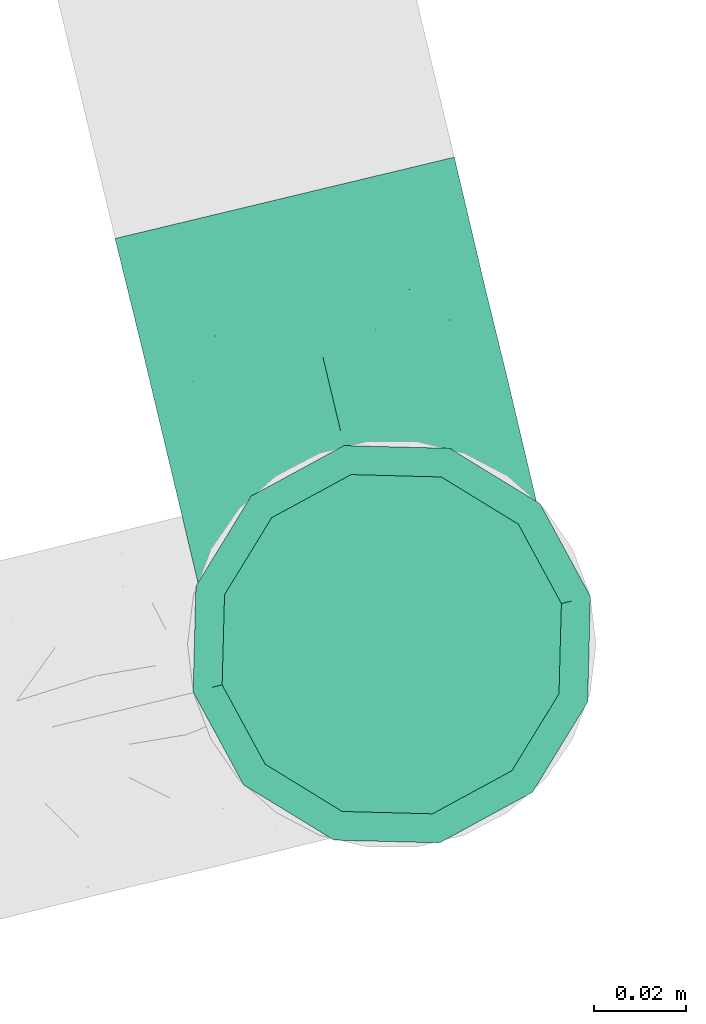
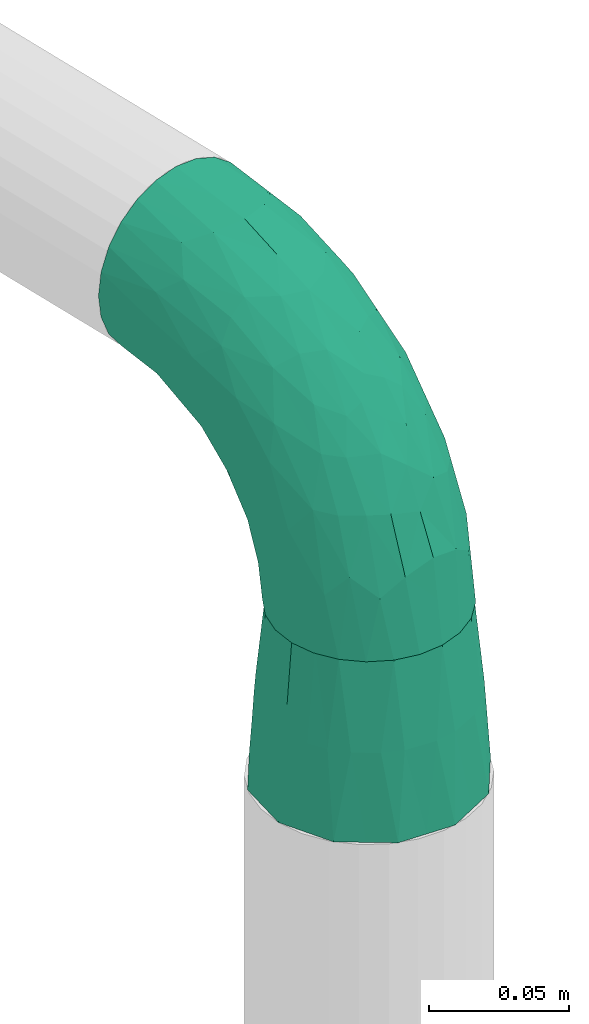
# One storey, part 87 of 93: 2 flow fittings.
"""IFC2X3 building model written with IfcOpenShell, lengths in millimetres."""

import ifcopenshell
import ifcopenshell.guid

model = None  # the IFC model being written
_history = None  # IfcOwnerHistory: only IFC2X3 demands one
_inside = {}  # id of a spatial element -> (the spatial element, [elements in it])
_under = {}  # id of a project, library or spatial element -> (it, [spatial elements below it])
_declared = {}  # id of a project -> (the project, [libraries it declares])
_typed = {}  # id of a type object -> (the type object, [elements of that type])
_made_of = {}  # id of a material, layer set ... -> (it, [elements and type objects made of it])


def new_model(schema):
    """Start an empty IFC model of exactly this schema.

    Asked for "IFC4X3", IfcOpenShell would pick the latest addendum, in which some entities
    have other attributes; the version numbers below select the first issue.
    IFC2X3 requires an IfcOwnerHistory on every rooted entity: one is made here for all.
    """
    global model, _history
    if schema == "IFC4X3":
        model = ifcopenshell.file(schema_version=(4, 3, 0, 0))
    else:
        model = ifcopenshell.file(schema=schema)
    _inside.clear()
    _under.clear()
    _declared.clear()
    _typed.clear()
    _made_of.clear()
    _history = None
    if model.schema == "IFC2X3":
        org = make("IfcOrganization", Name="unknown")
        user = make(
            "IfcPersonAndOrganization",
            ThePerson=make("IfcPerson", FamilyName="unknown"),
            TheOrganization=org,
        )
        app = make(
            "IfcApplication",
            ApplicationDeveloper=org,
            Version="unknown",
            ApplicationFullName="unknown",
            ApplicationIdentifier="unknown",
        )
        _history = make(
            "IfcOwnerHistory",
            OwningUser=user,
            OwningApplication=app,
            ChangeAction="ADDED",
            CreationDate=0,
        )
    return model


def make(cls, **values):
    """One entity of the class cls with the attributes given. An attribute that is None is left unset."""
    return model.create_entity(
        cls, **{name: value for name, value in values.items() if value is not None}
    )


def entity(cls, *values):
    """Any entity or typed value of the class cls, its attributes in the order of the schema. None: left unset."""
    e = model.create_entity(cls)
    for i, value in enumerate(values):
        if value is not None:
            e[i] = value
    return e


def rooted(cls, **values):
    """An entity with a GlobalId (a new one), such as an element, a storey or a relation."""
    return make(cls, GlobalId=ifcopenshell.guid.new(), OwnerHistory=_history, **values)


def si_unit(unit_type, name, prefix=None):
    """IfcSIUnit, for example si_unit("LENGTHUNIT", "METRE", prefix="MILLI")."""
    return make("IfcSIUnit", UnitType=unit_type, Prefix=prefix, Name=name)


def converted_unit(unit_type, name, factor, base, dimensions=None, offset=None):
    """IfcConversionBasedUnit, such as the inch: factor (a typed value) times the base unit."""
    return make(
        "IfcConversionBasedUnit"
        if offset is None
        else "IfcConversionBasedUnitWithOffset",
        ConversionOffset=offset,
        Dimensions=None
        if dimensions is None
        else entity("IfcDimensionalExponents", *dimensions),
        UnitType=unit_type,
        Name=name,
        ConversionFactor=make(
            "IfcMeasureWithUnit", ValueComponent=factor, UnitComponent=base
        ),
    )


def derived_unit(unit_type, elements):
    """IfcDerivedUnit: a product of units, each with its exponent."""
    return make(
        "IfcDerivedUnit",
        Elements=[
            make("IfcDerivedUnitElement", Unit=unit, Exponent=power)
            for unit, power in elements
        ],
        UnitType=unit_type,
    )


def assignment(units):
    """IfcUnitAssignment: the units of a project."""
    return None if units is None else make("IfcUnitAssignment", Units=units)


def point(xyz):
    """IfcCartesianPoint."""
    return None if xyz is None else make("IfcCartesianPoint", Coordinates=xyz)


def direction(xyz):
    """IfcDirection."""
    return None if xyz is None else make("IfcDirection", DirectionRatios=xyz)


def frame(location, z_axis=None, x_axis=None):
    """IfcAxis2Placement3D, a coordinate frame: its origin and axes. An axis left out is left unset."""
    return make(
        "IfcAxis2Placement3D",
        Location=point(location),
        Axis=direction(z_axis),
        RefDirection=direction(x_axis),
    )


def origin():
    """The frame at (0, 0, 0) with its axes left unset."""
    return frame((0.0, 0.0, 0.0))


def place(relative_to, where):
    """IfcLocalPlacement: puts the frame where relative to a parent placement (None: the world)."""
    return make(
        "IfcLocalPlacement", PlacementRelTo=relative_to, RelativePlacement=where
    )


def context(
    kind, dimensions, precision=None, world=None, true_north=None, identifier=None
):
    """IfcGeometricRepresentationContext, for example the 3D "Model" context."""
    return make(
        "IfcGeometricRepresentationContext",
        ContextIdentifier=identifier,
        ContextType=kind,
        CoordinateSpaceDimension=dimensions,
        Precision=precision,
        WorldCoordinateSystem=world,
        TrueNorth=true_north,
    )


def subcontext(parent, identifier, kind, view, scale=None):
    """IfcGeometricRepresentationSubContext, for example "Body" below "Model"."""
    return make(
        "IfcGeometricRepresentationSubContext",
        ContextIdentifier=identifier,
        ContextType=kind,
        ParentContext=parent,
        TargetScale=scale,
        TargetView=view,
    )


def project(units=None, contexts=None):
    """IfcProject with its units and contexts."""
    return rooted(
        "IfcProject",
        Name="project",
        RepresentationContexts=contexts,
        UnitsInContext=assignment(units),
    )


def spatial(cls, under=None, at=None, **own):
    """A site, building, storey or space (cls), placed at a placement, below another one or the project."""
    s = rooted(cls, ObjectPlacement=at, **own)
    if under is not None:
        _under.setdefault(under.id(), (under, []))[1].append(s)
    return s


def faces_of(points, faces, orient=None, outer=None):
    """IfcFace entities. A face is a list of loops; a loop is a list of indices into points, from 0.

    orient and outer hold one flag for each loop. By default every Orientation is true, the
    first loop of a face is its IfcFaceOuterBound and the others are IfcFaceBound.
    """
    made = []
    for i, loops in enumerate(faces):
        bounds = []
        for j, loop in enumerate(loops):
            is_outer = j == 0 if outer is None else outer[i][j]
            bounds.append(
                make(
                    "IfcFaceOuterBound" if is_outer else "IfcFaceBound",
                    Bound=make("IfcPolyLoop", Polygon=[points[k] for k in loop]),
                    Orientation=True if orient is None else orient[i][j],
                )
            )
        made.append(make("IfcFace", Bounds=bounds))
    return made


def faceted_brep(points, faces, orient=None, outer=None, voids=None):
    """IfcFacetedBrep: a solid bounded by flat faces; with voids (closed shells), ...WithVoids."""
    shared = [point(p) for p in points]
    hull = make("IfcClosedShell", CfsFaces=faces_of(shared, faces, orient, outer))
    if voids is None:
        return make("IfcFacetedBrep", Outer=hull)
    return make(
        "IfcFacetedBrepWithVoids",
        Outer=hull,
        Voids=[
            make(cls, CfsFaces=faces_of(shared, fs, o, b)) for cls, fs, o, b in voids
        ],
    )


def shape(context_of_items, identifier, shape_type, items):
    """IfcShapeRepresentation: the items that make up one representation, for example the "Body"."""
    return make(
        "IfcShapeRepresentation",
        ContextOfItems=context_of_items,
        RepresentationIdentifier=identifier,
        RepresentationType=shape_type,
        Items=items,
    )


def source(mapping_origin, context_of_items, identifier, shape_type, items):
    """IfcRepresentationMap: a shape defined once, which mapped items show again and again."""
    return make(
        "IfcRepresentationMap",
        MappingOrigin=mapping_origin,
        MappedRepresentation=shape(context_of_items, identifier, shape_type, items),
    )


def transform(
    local_origin,
    x_axis=None,
    y_axis=None,
    z_axis=None,
    scale=None,
    scale2=None,
    scale3=None,
    uniform=True,
):
    """IfcCartesianTransformationOperator3D, or its non-uniform kind. x_axis, y_axis, z_axis: its Axis1, 2, 3."""
    if uniform:
        return make(
            "IfcCartesianTransformationOperator3D",
            Axis1=direction(x_axis),
            Axis2=direction(y_axis),
            LocalOrigin=point(local_origin),
            Scale=scale,
            Axis3=direction(z_axis),
        )
    return make(
        "IfcCartesianTransformationOperator3DnonUniform",
        Axis1=direction(x_axis),
        Axis2=direction(y_axis),
        LocalOrigin=point(local_origin),
        Scale=scale,
        Axis3=direction(z_axis),
        Scale2=scale2,
        Scale3=scale3,
    )


def mapped(mapping_source, mapping_target):
    """IfcMappedItem: shows the shape of a source again, moved by a transform."""
    return make(
        "IfcMappedItem", MappingSource=mapping_source, MappingTarget=mapping_target
    )


def material(Name=None, Category=None):
    """IfcMaterial."""
    return make("IfcMaterial", Name=Name, Category=Category)


def made_of(thing, what):
    """Note that an element or type object is made of a material, layer set ...; save() writes the relation."""
    if what is not None:
        _made_of.setdefault(what.id(), (what, []))[1].append(thing)
    return thing


def type_object(cls, material=None, **own):
    """A type object (cls), such as IfcWallType, which elements share."""
    return made_of(rooted(cls, **own), material)


def type_shapes(of_type, sources):
    """Give a type object the sources (RepresentationMaps) that its elements show as mapped items."""
    of_type.RepresentationMaps = sources


def element(
    cls,
    number,
    at=None,
    inside=None,
    cuts=None,
    type_object=None,
    material=None,
    context=None,
    identifier="Body",
    shape_type=None,
    held_by="IfcProductDefinitionShape",
    body=None,
    shapes=None,
    **own,
):
    """One element of the class cls, such as IfcWall. Its Tag is "e" and its number.

    at: its placement. inside: the storey or other place that contains it. cuts: it is an
    opening in that element (IfcRelVoidsElement). A single representation is given by context,
    identifier, shape_type and body (its items); several are given by shapes. held_by: the class
    of the entity that holds the representations. save() writes the other relations.
    """
    e = rooted(cls, Tag="e%d" % number, ObjectPlacement=at, **own)
    if body is not None:
        shapes = [shape(context, identifier, shape_type, body)]
    if shapes is not None:
        e.Representation = make(held_by, Representations=shapes)
    if inside is not None:
        _inside.setdefault(inside.id(), (inside, []))[1].append(e)
    if cuts is not None:
        rooted(
            "IfcRelVoidsElement", RelatingBuildingElement=cuts, RelatedOpeningElement=e
        )
    if type_object is not None:
        _typed.setdefault(type_object.id(), (type_object, []))[1].append(e)
    return made_of(e, material)


def aggregate(whole, parts):
    """IfcRelAggregates: a whole, such as a stair, and the parts it consists of."""
    return rooted("IfcRelAggregates", RelatingObject=whole, RelatedObjects=parts)


def save(model, path):
    """Write the relations noted so far, then the file.

    IfcRelAggregates (storeys below a building ...), IfcRelContainedInSpatialStructure (elements
    in a storey), IfcRelDefinesByType, IfcRelAssociatesMaterial and IfcRelDeclares: one each for
    every whole, place, type object, material and project.
    """
    for whole, parts in _under.values():
        aggregate(whole, parts)
    for where, things in _inside.values():
        rooted(
            "IfcRelContainedInSpatialStructure",
            RelatedElements=things,
            RelatingStructure=where,
        )
    for kind, things in _typed.values():
        rooted("IfcRelDefinesByType", RelatedObjects=things, RelatingType=kind)
    for what, things in _made_of.values():
        rooted("IfcRelAssociatesMaterial", RelatedObjects=things, RelatingMaterial=what)
    for by, libraries in _declared.values():
        rooted("IfcRelDeclares", RelatingContext=by, RelatedDefinitions=libraries)
    model.write(path)


model = new_model("IFC2X3")

# Units and contexts
model_context = context("Model", 3, precision=0.01, world=origin(), true_north=direction((6.12303176911189e-17, 1.0)))
body_context = subcontext(model_context, "Body", "Model", "MODEL_VIEW")
ifc_project = project(units=[si_unit("LENGTHUNIT", "METRE", prefix="MILLI"), si_unit("AREAUNIT", "SQUARE_METRE"), si_unit("VOLUMEUNIT", "CUBIC_METRE"), converted_unit("PLANEANGLEUNIT", "DEGREE", entity("IfcRatioMeasure", 0.0174532925199433), si_unit("PLANEANGLEUNIT", "RADIAN"), dimensions=[0, 0, 0, 0, 0, 0, 0]), si_unit("MASSUNIT", "GRAM", prefix="KILO"), derived_unit("MASSDENSITYUNIT", [(si_unit("MASSUNIT", "GRAM", prefix="KILO"), 1), (si_unit("LENGTHUNIT", "METRE"), -3)]), derived_unit("MOMENTOFINERTIAUNIT", [(si_unit("LENGTHUNIT", "METRE"), 4)]), si_unit("TIMEUNIT", "SECOND"), si_unit("FREQUENCYUNIT", "HERTZ"), si_unit("THERMODYNAMICTEMPERATUREUNIT", "DEGREE_CELSIUS"), derived_unit("THERMALTRANSMITTANCEUNIT", [(si_unit("MASSUNIT", "GRAM", prefix="KILO"), 1), (si_unit("THERMODYNAMICTEMPERATUREUNIT", "KELVIN"), -1), (si_unit("TIMEUNIT", "SECOND"), -3)]), derived_unit("VOLUMETRICFLOWRATEUNIT", [(si_unit("LENGTHUNIT", "METRE"), 3), (si_unit("TIMEUNIT", "SECOND"), -1)]), derived_unit("MASSFLOWRATEUNIT", [(si_unit("MASSUNIT", "GRAM", prefix="KILO"), 1), (si_unit("TIMEUNIT", "SECOND"), -1)]), derived_unit("ROTATIONALFREQUENCYUNIT", [(si_unit("TIMEUNIT", "SECOND"), -1)]), si_unit("ELECTRICCURRENTUNIT", "AMPERE"), si_unit("ELECTRICVOLTAGEUNIT", "VOLT"), si_unit("POWERUNIT", "WATT"), si_unit("FORCEUNIT", "NEWTON", prefix="KILO"), si_unit("ILLUMINANCEUNIT", "LUX"), si_unit("LUMINOUSFLUXUNIT", "LUMEN"), si_unit("LUMINOUSINTENSITYUNIT", "CANDELA"), derived_unit("USERDEFINED", [(si_unit("MASSUNIT", "GRAM", prefix="KILO"), -1), (si_unit("LENGTHUNIT", "METRE"), -2), (si_unit("TIMEUNIT", "SECOND"), 3), (si_unit("LUMINOUSFLUXUNIT", "LUMEN"), 1)]), derived_unit("LINEARVELOCITYUNIT", [(si_unit("LENGTHUNIT", "METRE"), 1), (si_unit("TIMEUNIT", "SECOND"), -1)]), si_unit("PRESSUREUNIT", "PASCAL"), derived_unit("USERDEFINED", [(si_unit("LENGTHUNIT", "METRE"), -2), (si_unit("MASSUNIT", "GRAM", prefix="KILO"), 1), (si_unit("TIMEUNIT", "SECOND"), -2)]), derived_unit("LINEARFORCEUNIT", [(si_unit("MASSUNIT", "GRAM", prefix="KILO"), 1), (si_unit("LENGTHUNIT", "METRE"), 1), (si_unit("TIMEUNIT", "SECOND"), -2), (si_unit("LENGTHUNIT", "METRE"), -1)]), derived_unit("PLANARFORCEUNIT", [(si_unit("MASSUNIT", "GRAM", prefix="KILO"), 1), (si_unit("LENGTHUNIT", "METRE"), 1), (si_unit("TIMEUNIT", "SECOND"), -2), (si_unit("LENGTHUNIT", "METRE"), -2)])], contexts=[model_context])

# Site, building, storey
site_placement = place(None, origin())
site = spatial("IfcSite", under=ifc_project, at=site_placement, CompositionType="ELEMENT")
building_placement = place(site_placement, origin())
building = spatial("IfcBuilding", under=site, at=building_placement, CompositionType="ELEMENT")
storey_placement = place(building_placement, frame((0.0, 0.0, -4200.0)))
storey = spatial("IfcBuildingStorey", under=building, at=storey_placement, CompositionType="ELEMENT", Elevation=-4200.0)

# Flow fittings
ifc_material = material()
pipe_fitting_type_1 = type_object("IfcPipeFittingType", Name="ADSK_2", PredefinedType="NOTDEFINED", material=ifc_material)
shared_shape_1 = source(origin(), body_context, "Body", "Brep", [
    faceted_brep([(-100.0, 19.0, -32.91), (-100.0, 9.84, -36.71), (-100.0, 0.0, -38.0), (-100.0, -9.84, -36.71), (-100.0, -19.0, -32.91), (-100.0, -26.87, -26.87), (-100.0, -32.91, -19.0), (-100.0, -36.71, -9.84), (-100.0, -38.0, 0.0), (-100.0, -36.71, 9.84), (-100.0, -32.91, 19.0), (-100.0, -26.87, 26.87), (-100.0, -19.0, 32.91), (-100.0, -9.84, 36.71), (-100.0, 0.0, 38.0), (-100.0, 9.84, 36.71), (-100.0, 19.0, 32.91), (-100.0, 26.87, 26.87), (-100.0, 32.91, 19.0), (-100.0, 36.71, 9.84), (-100.0, 38.0, 0.0), (-100.0, 36.71, -9.84), (-100.0, 32.91, -19.0), (-100.0, 26.87, -26.87), (0.0, 100.0, -38.0), (-9.83, 100.0, -36.71), (-19.0, 100.0, -32.91), (-26.87, 100.0, -26.87), (-32.91, 100.0, -19.0), (-36.7, 100.0, -9.84), (-38.0, 100.0, 0.0), (-36.7, 100.0, 9.84), (-32.91, 100.0, 19.0), (-26.87, 100.0, 26.87), (-19.0, 100.0, 32.91), (-9.83, 100.0, 36.71), (0.0, 100.0, 38.0), (9.84, 100.0, 36.71), (19.0, 100.0, 32.91), (26.87, 100.0, 26.87), (32.91, 100.0, 19.0), (36.71, 100.0, 9.84), (38.0, 100.0, 0.0), (36.71, 100.0, -9.84), (32.91, 100.0, -19.0), (26.87, 100.0, -26.87), (19.0, 100.0, -32.91), (9.84, 100.0, -36.71), (-40.69, 71.44, 16.62), (-81.22, -35.53, 0.0), (-67.52, -31.95, 12.5), (-8.97, -2.95, 6.59), (-11.71, -2.76, 13.62), (-24.68, -14.61, 8.04), (-64.28, -33.3, 0.0), (-83.72, 23.85, 30.89), (-76.19, 33.07, 24.6), (-74.13, -28.58, 21.76), (13.92, 43.47, 26.56), (5.03, 42.28, 32.41), (2.17, 22.78, 25.61), (20.11, 65.77, 28.71), (-65.77, -20.11, 28.71), (-74.23, -13.22, 34.41), (-44.44, -24.14, 12.16), (-47.64, -26.4, 0.0), (-31.0, -19.51, 0.0), (-54.86, 48.59, 21.12), (-81.55, 37.18, 15.86), (-42.28, -5.03, 32.41), (-52.67, 2.67, 37.1), (-14.76, 85.65, 35.5), (-6.46, 75.04, 37.87), (-58.38, 40.19, 26.6), (-15.88, 37.27, 37.68), (-29.21, 13.39, 36.1), (-10.53, 30.95, 35.7), (-77.78, -4.12, 37.45), (-2.67, 52.67, 37.1), (-76.41, 41.64, 8.45), (-71.15, 7.29, 37.89), (-32.26, 79.13, 24.41), (-44.28, 53.84, 26.08), (-25.18, 76.9, 31.2), (19.6, 43.38, 19.97), (6.25, 18.29, 16.9), (19.92, 34.73, 10.46), (-60.8, 50.97, 7.63), (-76.27, 42.72, 0.0), (-77.34, 15.98, 35.72), (-15.11, 15.11, 32.27), (-22.78, -2.17, 25.61), (28.58, 74.12, 21.76), (31.95, 67.52, 12.5), (-51.02, 30.39, 34.96), (-54.69, 20.06, 37.12), (26.4, 47.64, 0.0), (-51.15, 12.85, 38.0), (-32.84, 22.95, 37.94), (4.12, 77.78, 37.45), (-43.38, -19.6, 19.97), (35.53, 81.22, 0.0), (13.22, 74.23, 34.41), (-39.82, 82.33, 7.34), (-42.72, 76.27, 0.0), (-33.83, 52.47, 33.18), (-48.09, 40.81, 31.48), (-56.16, 56.16, 0.0), (-48.2, 64.18, 8.55), (-18.69, 66.93, 35.98), (-49.98, 57.58, 16.12), (-62.54, 46.99, 14.59), (-43.26, -12.84, 27.42), (-17.52, 48.72, 37.89), (-64.19, 29.4, 31.78), (-27.05, 50.9, 36.03), (-36.14, 36.14, 36.75), (-23.99, -8.71, 19.44), (6.3, 13.34, 7.98), (19.51, 31.0, 0.0), (-7.64, 6.3, 21.15), (-16.71, -8.55, 0.0), (33.3, 64.28, 0.0), (-2.42, 2.42, 0.0), (8.55, 16.71, 0.0), (-85.65, 14.76, -35.5), (-23.85, 83.72, -30.89), (-33.07, 76.19, -24.6), (-75.04, 6.46, -37.87), (-37.27, 15.88, -37.68), (-13.39, 29.21, -36.1), (-30.95, 10.53, -35.7), (-79.13, 32.26, -24.41), (-76.9, 25.18, -31.2), (6.3, 13.34, -7.98), (-11.71, -2.76, -13.62), (6.25, 18.29, -16.9), (-82.33, 39.82, -7.34), (-66.93, 18.69, -35.98), (-48.72, 17.52, -37.89), (-64.18, 48.2, -8.55), (31.95, 67.52, -12.5), (28.58, 74.12, -21.76), (-52.47, 33.83, -33.18), (4.12, 77.78, -37.45), (-7.29, 71.15, -37.89), (-15.98, 77.34, -35.72), (-67.52, -31.95, -12.5), (-30.39, 51.02, -34.96), (-20.06, 54.69, -37.12), (-48.59, 54.86, -21.12), (-37.18, 81.56, -15.86), (-74.13, -28.58, -21.76), (-29.4, 64.19, -31.78), (-40.81, 48.09, -31.48), (-40.19, 58.38, -26.6), (-65.77, -20.11, -28.71), (-74.23, -13.22, -34.41), (-39.81, -22.62, -10.22), (-77.78, -4.12, -37.45), (-43.38, -19.6, -19.97), (-12.85, 51.15, -38.0), (-22.95, 32.84, -37.94), (-71.44, 40.69, -16.62), (19.6, 43.38, -19.97), (20.11, 65.77, -28.71), (-52.67, 2.67, -37.1), (-53.84, 44.28, -26.08), (-41.64, 76.41, -8.45), (-23.99, -8.71, -19.44), (-43.47, -13.92, -26.56), (-22.78, -2.17, -25.61), (-20.59, -12.11, -6.83), (13.22, 74.23, -34.41), (5.03, 42.28, -32.41), (-2.67, 52.67, -37.1), (19.92, 34.73, -10.46), (-42.28, -5.03, -32.41), (12.84, 43.26, -27.42), (-50.97, 60.8, -7.63), (-57.58, 49.98, -16.12), (-46.99, 62.54, -14.59), (-50.9, 27.05, -36.03), (-15.11, 15.11, -32.27), (2.17, 22.78, -25.61), (-36.14, 36.14, -36.75), (-7.64, 6.3, -21.15), (-6.28, -0.33, -7.3)], [[[0, 1, 2, 3, 4, 5, 6, 7, 8, 9, 10, 11, 12, 13, 14, 15, 16, 17, 18, 19, 20, 21, 22, 23]], [[24, 25, 26, 27, 28, 29, 30, 31, 32, 33, 34, 35, 36, 37, 38, 39, 40, 41, 42, 43, 44, 45, 46, 47]], [[32, 31, 48]], [[49, 50, 9]], [[51, 52, 53]], [[9, 50, 10]], [[54, 50, 49]], [[17, 55, 56]], [[11, 10, 57]], [[58, 59, 60]], [[61, 39, 38]], [[62, 12, 11]], [[62, 63, 12]], [[64, 65, 66]], [[56, 67, 68]], [[63, 69, 70]], [[35, 71, 72]], [[67, 56, 73]], [[74, 75, 76]], [[16, 55, 17]], [[13, 77, 14]], [[76, 78, 74]], [[68, 79, 19]], [[18, 17, 56]], [[14, 77, 80]], [[20, 19, 79]], [[81, 82, 83]], [[84, 85, 86]], [[87, 88, 79]], [[18, 68, 19]], [[15, 89, 16]], [[14, 80, 15]], [[85, 84, 60]], [[90, 69, 91]], [[92, 84, 93]], [[94, 89, 95]], [[86, 96, 93]], [[83, 71, 34]], [[95, 97, 98]], [[37, 36, 99]], [[40, 39, 92]], [[40, 93, 41]], [[66, 53, 64]], [[92, 93, 40]], [[57, 100, 62]], [[93, 101, 41]], [[93, 84, 86]], [[61, 102, 59]], [[34, 33, 83]], [[103, 48, 31]], [[50, 57, 10]], [[104, 103, 30]], [[94, 105, 106]], [[104, 107, 108]], [[12, 63, 13]], [[83, 109, 71]], [[83, 105, 109]], [[33, 81, 83]], [[67, 110, 111]], [[108, 103, 104]], [[112, 69, 62]], [[34, 71, 35]], [[36, 35, 72]], [[109, 113, 72]], [[102, 38, 37]], [[102, 61, 38]], [[114, 106, 73]], [[89, 15, 80]], [[33, 32, 81]], [[115, 105, 116]], [[109, 115, 113]], [[99, 72, 78]], [[111, 87, 79]], [[108, 87, 110]], [[69, 63, 62]], [[77, 63, 70]], [[100, 117, 112]], [[69, 90, 75]], [[99, 102, 37]], [[78, 76, 59]], [[78, 59, 102]], [[59, 90, 60]], [[100, 57, 50]], [[62, 11, 57]], [[39, 61, 92]], [[84, 92, 61]], [[95, 89, 80]], [[55, 89, 114]], [[83, 82, 105]], [[94, 106, 114]], [[98, 113, 116]], [[78, 72, 113]], [[98, 116, 95]], [[98, 70, 75]], [[32, 48, 81]], [[82, 81, 48]], [[91, 112, 117]], [[60, 84, 58]], [[113, 115, 116]], [[118, 119, 86]], [[90, 91, 60]], [[91, 117, 120]], [[72, 99, 36]], [[102, 99, 78]], [[63, 77, 13]], [[80, 77, 70]], [[95, 80, 97]], [[94, 95, 116]], [[56, 68, 18]], [[79, 68, 111]], [[110, 87, 111]], [[79, 88, 20]], [[108, 107, 87]], [[88, 87, 107]], [[120, 60, 91]], [[66, 121, 53]], [[118, 86, 85]], [[122, 93, 96]], [[52, 118, 85]], [[118, 123, 124, 119]], [[48, 103, 108]], [[30, 103, 31]], [[89, 55, 16]], [[56, 55, 114]], [[80, 70, 97]], [[70, 98, 97]], [[105, 94, 116]], [[89, 94, 114]], [[105, 82, 106]], [[73, 106, 82]], [[67, 73, 82]], [[114, 73, 56]], [[110, 82, 48]], [[67, 111, 68]], [[82, 110, 67]], [[108, 110, 48]], [[69, 75, 70]], [[76, 75, 90]], [[59, 76, 90]], [[78, 113, 74]], [[113, 98, 74]], [[75, 74, 98]], [[9, 8, 49]], [[101, 93, 122]], [[101, 42, 41]], [[72, 71, 109]], [[50, 54, 65]], [[117, 53, 52]], [[109, 105, 115]], [[100, 112, 62]], [[91, 69, 112]], [[123, 51, 121]], [[120, 52, 85]], [[52, 120, 117]], [[60, 120, 85]], [[51, 118, 52]], [[100, 64, 117]], [[50, 64, 100]], [[121, 51, 53]], [[118, 51, 123]], [[84, 61, 58]], [[59, 58, 61]], [[86, 119, 96]], [[65, 64, 50]], [[117, 64, 53]], [[125, 1, 0]], [[27, 126, 127]], [[2, 1, 128]], [[129, 130, 131]], [[132, 133, 23]], [[134, 135, 136]], [[88, 137, 20]], [[138, 139, 128]], [[88, 107, 140]], [[141, 142, 44]], [[138, 133, 143]], [[24, 144, 145]], [[146, 25, 145]], [[125, 133, 138]], [[6, 147, 7]], [[148, 146, 149]], [[147, 49, 7]], [[127, 150, 151]], [[147, 6, 152]], [[153, 154, 155]], [[156, 4, 157]], [[140, 137, 88]], [[24, 145, 25]], [[43, 42, 101]], [[65, 147, 158]], [[148, 143, 154]], [[159, 3, 2]], [[147, 152, 160]], [[149, 161, 162]], [[156, 5, 4]], [[137, 163, 21]], [[142, 164, 165]], [[131, 166, 129]], [[28, 151, 29]], [[167, 133, 132]], [[168, 30, 29]], [[169, 170, 171]], [[127, 28, 27]], [[150, 127, 155]], [[135, 172, 158]], [[26, 25, 146]], [[1, 125, 128]], [[22, 21, 163]], [[126, 27, 26]], [[151, 168, 29]], [[24, 47, 144]], [[45, 165, 46]], [[0, 23, 133]], [[173, 174, 175]], [[119, 134, 176]], [[142, 45, 44]], [[173, 46, 165]], [[141, 44, 43]], [[46, 173, 47]], [[141, 101, 122]], [[156, 157, 177]], [[157, 4, 3]], [[101, 141, 43]], [[178, 174, 165]], [[169, 160, 170]], [[6, 5, 152]], [[170, 177, 171]], [[158, 147, 160]], [[104, 168, 179]], [[141, 96, 176]], [[150, 180, 181]], [[23, 22, 132]], [[138, 143, 182]], [[138, 182, 139]], [[159, 128, 166]], [[181, 179, 168]], [[140, 179, 180]], [[159, 157, 3]], [[166, 131, 177]], [[166, 177, 157]], [[177, 183, 171]], [[174, 173, 165]], [[144, 173, 175]], [[178, 164, 184]], [[174, 183, 130]], [[5, 156, 152]], [[160, 152, 156]], [[164, 142, 141]], [[165, 45, 142]], [[149, 146, 145]], [[126, 146, 153]], [[133, 167, 143]], [[148, 154, 153]], [[162, 139, 185]], [[166, 128, 139]], [[162, 185, 149]], [[162, 175, 130]], [[22, 163, 132]], [[167, 132, 163]], [[174, 184, 183]], [[136, 176, 134]], [[184, 136, 186]], [[158, 172, 66]], [[136, 184, 164]], [[171, 183, 184]], [[128, 159, 2]], [[157, 159, 166]], [[173, 144, 47]], [[145, 144, 175]], [[149, 145, 161]], [[148, 149, 185]], [[127, 151, 28]], [[168, 151, 181]], [[180, 179, 181]], [[168, 104, 30]], [[140, 107, 179]], [[104, 179, 107]], [[176, 136, 164]], [[135, 169, 186]], [[141, 176, 164]], [[134, 119, 124, 123]], [[158, 66, 65]], [[187, 172, 135]], [[163, 137, 140]], [[20, 137, 21]], [[146, 126, 26]], [[127, 126, 153]], [[145, 175, 161]], [[175, 162, 161]], [[143, 148, 185]], [[146, 148, 153]], [[143, 167, 154]], [[155, 154, 167]], [[150, 155, 167]], [[153, 155, 127]], [[180, 167, 163]], [[150, 181, 151]], [[167, 180, 150]], [[140, 180, 163]], [[174, 130, 175]], [[131, 130, 183]], [[177, 131, 183]], [[166, 139, 129]], [[139, 162, 129]], [[130, 129, 162]], [[49, 147, 54]], [[49, 8, 7]], [[133, 125, 0]], [[128, 125, 138]], [[158, 160, 169]], [[65, 54, 147]], [[187, 135, 134]], [[187, 121, 172]], [[134, 123, 187]], [[143, 185, 182]], [[121, 187, 123]], [[121, 66, 172]], [[139, 182, 185]], [[160, 156, 170]], [[177, 170, 156]], [[186, 169, 171]], [[158, 169, 135]], [[184, 186, 171]], [[135, 186, 136]], [[164, 178, 165]], [[184, 174, 178]], [[96, 141, 122]], [[96, 119, 176]]]),
])
type_shapes(pipe_fitting_type_1, [shared_shape_1])
flow_fitting_1_placement = place(storey_placement, frame((-11425.65, 11491.65, 2700.0), z_axis=(-0.972416614732459, -0.233250782190038, 3.49840318148723e-09), x_axis=(9.48106850804611e-08, -3.80264886625999e-07, 1.0)))
element("IfcFlowFitting", 1, at=flow_fitting_1_placement, inside=storey, type_object=pipe_fitting_type_1, material=ifc_material, Name="ADSK_2", ObjectType="ADSK_2", context=body_context, shape_type="MappedRepresentation", body=[
    mapped(shared_shape_1, transform((0.0, 0.0, 0.0), scale=1.0)),
])
pipe_fitting_type_2 = type_object("IfcPipeFittingType", Name="ADSK_2", PredefinedType="NOTDEFINED", material=ifc_material)
shared_shape_2 = source(origin(), body_context, "Body", "Brep", [
    faceted_brep([(75.0, 32.91, 19.0), (75.0, 25.95, 25.95), (75.0, 19.0, 32.91), (75.0, 9.5, 35.45), (75.0, 0.0, 38.0), (75.0, -9.5, 35.45), (75.0, -19.0, 32.91), (75.0, -25.95, 25.95), (75.0, -32.91, 19.0), (75.0, -35.45, 9.5), (75.0, -38.0, 0.0), (75.0, -35.45, -9.5), (75.0, -32.91, -19.0), (75.0, -25.95, -25.95), (75.0, -19.0, -32.91), (75.0, -9.5, -35.45), (75.0, 0.0, -38.0), (75.0, 9.5, -35.45), (75.0, 19.0, -32.91), (75.0, 25.95, -25.95), (75.0, 32.91, -19.0), (75.0, 35.45, -9.5), (75.0, 38.0, 0.0), (75.0, 35.45, 9.5), (0.0, -38.54, 22.25), (0.0, -30.39, 30.39), (0.0, -22.25, 38.54), (0.0, -11.12, 41.52), (0.0, 0.0, 44.5), (0.0, 11.13, 41.52), (0.0, 22.25, 38.54), (0.0, 30.39, 30.39), (0.0, 38.54, 22.25), (0.0, 41.52, 11.13), (0.0, 44.5, 0.0), (0.0, 41.52, -11.13), (0.0, 38.54, -22.25), (0.0, 30.39, -30.39), (0.0, 22.25, -38.54), (0.0, 11.12, -41.52), (0.0, 0.0, -44.5), (0.0, -11.13, -41.52), (0.0, -22.25, -38.54), (0.0, -30.39, -30.39), (0.0, -38.54, -22.25), (0.0, -41.52, -11.12), (0.0, -44.5, 0.0), (0.0, -41.52, 11.13), (37.5, -32.73, -25.11), (37.5, -25.11, -32.73), (37.5, -5.38, -40.9), (37.5, -17.77, -37.23), (37.5, -37.23, -17.77), (37.5, -39.96, -10.25), (37.5, 32.73, -25.11), (49.2, -40.24, 0.0), (49.2, 40.24, 0.0), (37.5, 3.22, -41.12), (37.5, 15.79, -38.11), (37.5, 23.35, -34.0), (37.5, 37.23, -17.77), (37.5, 39.96, -10.25), (37.5, 32.73, 25.11), (37.5, 25.11, 32.73), (37.5, 5.38, 40.9), (37.5, 17.77, 37.23), (37.5, 37.23, 17.77), (37.5, 39.96, 10.25), (37.5, -32.73, 25.11), (37.5, -3.22, 41.12), (37.5, -15.79, 38.11), (37.5, -23.35, 34.0), (37.5, -37.23, 17.77), (37.5, -39.96, 10.25)], [[[0, 1, 2, 3, 4, 5, 6, 7, 8, 9, 10, 11, 12, 13, 14, 15, 16, 17, 18, 19, 20, 21, 22, 23]], [[24, 25, 26, 27, 28, 29, 30, 31, 32, 33, 34, 35, 36, 37, 38, 39, 40, 41, 42, 43, 44, 45, 46, 47]], [[48, 49, 13]], [[50, 15, 51]], [[49, 43, 42]], [[52, 11, 53]], [[12, 52, 48]], [[52, 44, 48]], [[51, 49, 42]], [[12, 48, 13]], [[51, 14, 49]], [[49, 48, 43]], [[50, 41, 40]], [[44, 43, 48]], [[36, 54, 37]], [[45, 44, 52]], [[55, 11, 10]], [[21, 56, 22]], [[57, 16, 50]], [[58, 39, 38]], [[53, 45, 52]], [[58, 59, 18]], [[60, 20, 54]], [[53, 46, 45]], [[52, 12, 11]], [[50, 51, 41]], [[51, 42, 41]], [[13, 49, 14]], [[15, 14, 51]], [[57, 50, 40]], [[15, 50, 16]], [[59, 58, 38]], [[58, 57, 39]], [[57, 40, 39]], [[58, 17, 57]], [[17, 16, 57]], [[17, 58, 18]], [[60, 54, 36]], [[54, 59, 37]], [[59, 38, 37]], [[54, 19, 59]], [[19, 18, 59]], [[19, 54, 20]], [[61, 21, 60]], [[60, 35, 61]], [[60, 36, 35]], [[11, 55, 53]], [[21, 20, 60]], [[34, 56, 61]], [[46, 53, 55]], [[34, 61, 35]], [[56, 21, 61]], [[62, 63, 1]], [[64, 3, 65]], [[63, 31, 30]], [[66, 23, 67]], [[0, 66, 62]], [[66, 32, 62]], [[65, 63, 30]], [[0, 62, 1]], [[65, 2, 63]], [[63, 62, 31]], [[64, 29, 28]], [[32, 31, 62]], [[24, 68, 25]], [[33, 32, 66]], [[56, 23, 22]], [[9, 55, 10]], [[69, 4, 64]], [[70, 27, 26]], [[67, 33, 66]], [[70, 71, 6]], [[72, 8, 68]], [[67, 34, 33]], [[66, 0, 23]], [[64, 65, 29]], [[65, 30, 29]], [[1, 63, 2]], [[3, 2, 65]], [[69, 64, 28]], [[3, 64, 4]], [[71, 70, 26]], [[70, 69, 27]], [[69, 28, 27]], [[70, 5, 69]], [[5, 4, 69]], [[5, 70, 6]], [[72, 68, 24]], [[68, 71, 25]], [[71, 26, 25]], [[68, 7, 71]], [[7, 6, 71]], [[7, 68, 8]], [[73, 9, 72]], [[72, 47, 73]], [[72, 24, 47]], [[23, 56, 67]], [[9, 8, 72]], [[46, 55, 73]], [[34, 67, 56]], [[46, 73, 47]], [[55, 9, 73]]]),
])
type_shapes(pipe_fitting_type_2, [shared_shape_2])
flow_fitting_2_placement = place(storey_placement, frame((-11425.65, 11491.65, 2525.0), z_axis=(-0.233250782190034, 0.972416614732381, 3.91890560209467e-07), x_axis=(9.48106850804611e-08, -3.80264886625999e-07, 1.0)))
element("IfcFlowFitting", 2, at=flow_fitting_2_placement, inside=storey, type_object=pipe_fitting_type_2, material=ifc_material, Name="ADSK_2", ObjectType="ADSK_2", context=body_context, shape_type="MappedRepresentation", body=[
    mapped(shared_shape_2, transform((0.0, 0.0, 0.0), scale=1.0)),
])

save(model, "model.ifc")
